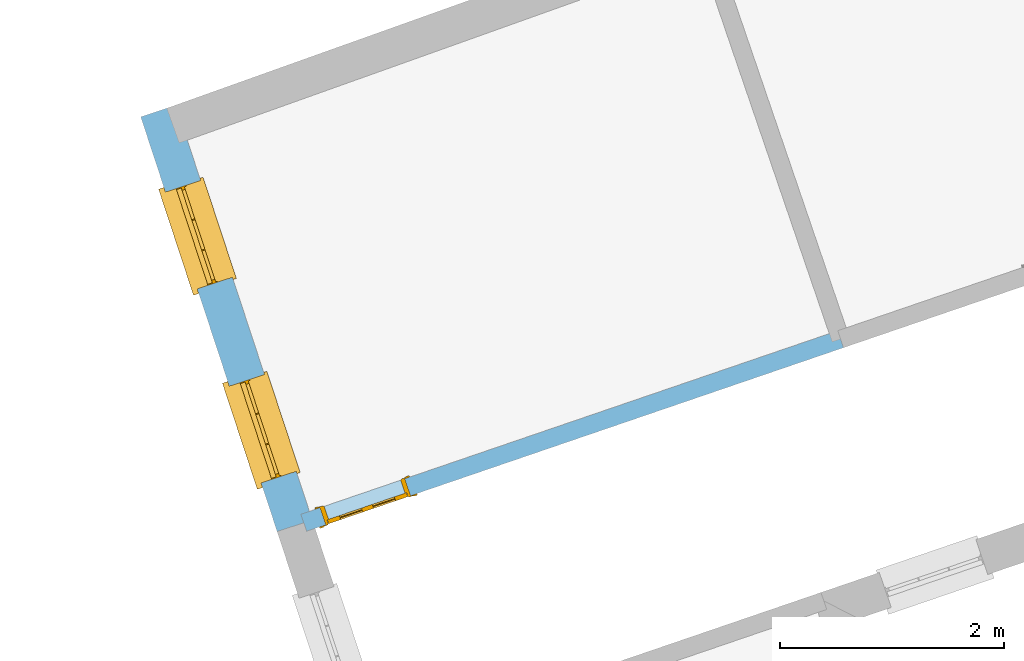
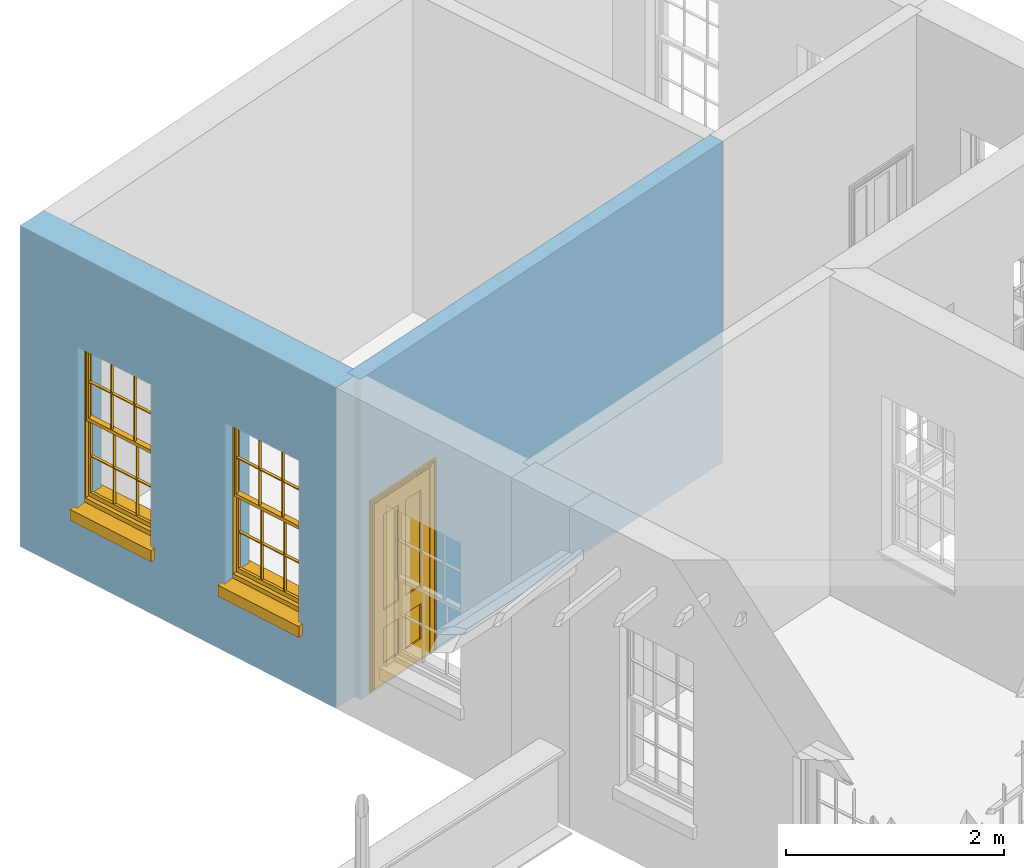
# One storey, part 6 of 10: 2 windows, 1 door, 3 openings, plus 2 elements that do not belong to this part.
"""IFC2X3 building model written with IfcOpenShell, lengths in metres."""

from ifc_helpers import new_model, si_unit, frame, origin, place, context, subcontext, project, spatial, polyline, outline, extrude, faceted_brep, material, layer, layer_set, layer_usage, element, fill, save


model = new_model("IFC2X3")

# Units and contexts
model_context = context("Model", 3, world=origin())
body_context = subcontext(model_context, "Body", "Model", "MODEL_VIEW")
ifc_project = project(units=[si_unit("PLANEANGLEUNIT", "RADIAN"), si_unit("MASSUNIT", "GRAM", prefix="KILO"), si_unit("FORCEUNIT", "NEWTON", prefix="KILO"), si_unit("LENGTHUNIT", "METRE")], contexts=[model_context])

# Site, building, storey
site_placement = place(None, origin())
site = spatial("IfcSite", under=ifc_project, at=site_placement, CompositionType="ELEMENT")
building_placement = place(None, origin())
building = spatial("IfcBuilding", under=site, at=building_placement, Name="Building plot-2", CompositionType="ELEMENT")
storey_placement = place(None, frame((0.0, 0.0, 4.6)))
storey = spatial("IfcBuildingStorey", under=building, at=storey_placement, Name="Floor 1", CompositionType="ELEMENT", Elevation=4.6)

# Wall, openings, windows
ifc_material_1 = material(Name="Masonry")
ifc_layer_1 = layer(ifc_material_1, 0.33, ventilated=False)
ifc_layer_set_1 = layer_set([ifc_layer_1], Name="My Wall")
ifc_layer_usage_1 = layer_usage(ifc_layer_set_1, "AXIS2", "NEGATIVE", 0.08)
wall_1_placement = place(storey_placement, origin())
wall_1 = element("IfcWallStandardCase", 1, at=wall_1_placement, inside=storey, material=ifc_layer_usage_1, Name="exterior", context=body_context, shape_type="SweptSolid", body=[
    extrude(outline(polyline([(27.5493804790374, 37.1006395888727), (27.2359079930561, 36.9975134499325), (28.4528876869268, 33.2982607294562), (28.7663601729081, 33.4013868683963), (27.5493804790374, 37.1006395888727)])), origin(), (0.0, 0.0, 1.0), 3.6),
])
opening_1_placement = place(storey_placement, frame((0.0, 0.0, 0.75)))
opening_1 = element("IfcOpeningElement", 2, at=opening_1_placement, cuts=wall_1, Name="Opening", ObjectType="Opening", context=body_context, shape_type="SweptSolid", body=[
    extrude(outline(polyline([(27.456558243292, 36.3268029667832), (27.7409363840057, 35.4623788387741), (28.054408869987, 35.5655049777142), (27.7700307292734, 36.4299291057233), (27.456558243292, 36.3268029667832)])), origin(), (0.0, 0.0, 1.0), 1.82),
])
opening_2_placement = place(storey_placement, frame((0.0, 0.0, 0.75)))
opening_2 = element("IfcOpeningElement", 3, at=opening_2_placement, cuts=wall_1, Name="Opening", ObjectType="Opening", context=body_context, shape_type="SweptSolid", body=[
    extrude(outline(polyline([(28.0259851588106, 34.5959161845682), (28.3103632995243, 33.7314920565591), (28.6238357855056, 33.8346181954992), (28.339457644792, 34.6990423235083), (28.0259851588106, 34.5959161845682)])), origin(), (0.0, 0.0, 1.0), 1.82),
])
window_1_placement = place(storey_placement, frame((27.6940373993385, 36.4049288296166, 0.75), z_axis=(0.0, 0.0, 1.0), x_axis=(0.284378140713617, -0.864424128009077, 0.0)))
window_1 = element("IfcWindow", 4, at=window_1_placement, inside=storey, Name="bedroom outside window", OverallHeight=1.82, OverallWidth=0.91, context=body_context, shape_type="Brep", held_by="IfcProductRepresentation", body=[
    faceted_brep([(0.033125, -0.105, 0.975209), (0.01, -0.105, 0.975209), (0.033125, -0.105, 1.376042), (0.876875, -0.105, 0.975209), (0.876875, -0.105, 1.376042), (0.9, -0.105, 0.975209), (0.876875, -0.105, 1.386042), (0.876875, -0.105, 1.786875), (0.9, -0.105, 1.81), (0.033125, -0.105, 1.786875), (0.033125, -0.105, 1.386042), (0.01, -0.105, 1.81), (0.876875, -0.135, 1.376042), (0.876875, -0.135, 0.975209), (0.9, -0.135, 0.937083), (0.033125, -0.135, 1.786875), (0.01, -0.135, 1.81), (0.033125, -0.135, 1.386042), (0.01, -0.135, 0.937083), (0.033125, -0.135, 0.975209), (0.033125, -0.135, 1.376042), (0.876875, -0.135, 1.786875), (0.876875, -0.135, 1.386042), (0.9, -0.135, 1.81), (0.033125, -0.105, 0.937083), (0.01, -0.105, 0.937083), (0.033125, -0.105, 0.53625), (0.876875, -0.105, 0.937083), (0.876875, -0.105, 0.53625), (0.9, -0.105, 0.937083), (0.876875, -0.105, 0.52625), (0.876875, -0.105, 0.125417), (0.9, -0.105, 0.077167), (0.033125, -0.105, 0.125417), (0.033125, -0.105, 0.52625), (0.01, -0.105, 0.077167), (-0.0425, -0.25, 0.01), (-0.0425, -0.3, 0.001667), (0.0, -0.25, 0.01), (0.9525, -0.25, 0.01), (0.91, -0.25, 0.01), (0.9525, -0.3, 0.001667), (-0.02, 0.08, 0.077167), (0.0, 0.08, 0.077167), (-0.02, 0.11, 0.077167), (0.0, -0.06, 0.077167), (0.01, -0.06, 0.077167), (0.91, -0.06, 0.077167), (0.91, 0.08, 0.077167), (0.9, -0.06, 0.077167), (0.93, 0.08, 0.077167), (0.93, 0.11, 0.077167), (0.01, -0.075, 0.975209), (0.9, -0.075, 0.975209), (0.876875, -0.075, 0.125417), (0.876875, -0.075, 0.52625), (0.9, -0.075, 0.077167), (0.876875, -0.075, 0.53625), (0.876875, -0.075, 0.937083), (0.033125, -0.075, 0.125417), (0.01, -0.075, 0.077167), (0.033125, -0.075, 0.52625), (0.033125, -0.075, 0.937083), (0.033125, -0.075, 0.53625), (-0.02, 0.08, 0.052167), (-0.02, 0.11, 0.052167), (0.93, 0.11, 0.052167), (0.93, 0.08, 0.052167), (0.91, 0.08, 0.052167), (0.0, 0.08, 0.052167), (0.91, -0.15, 0.026667), (0.0, -0.15, 0.026667), (-0.0425, -0.3, -0.123333), (0.9525, -0.3, -0.123333), (-0.0425, -0.25, -0.123333), (0.9525, -0.25, -0.123333), (0.01, -0.06, 1.81), (0.9, -0.06, 1.81), (0.0, -0.06, 1.82), (0.91, -0.06, 1.82), (0.01, -0.15, 0.077167), (0.9, -0.15, 0.077167), (0.592292, -0.105, 0.125417), (0.592292, -0.075, 0.125417), (0.317708, -0.075, 0.125417), (0.317708, -0.105, 0.125417), (0.592292, -0.105, 0.53625), (0.317708, -0.105, 0.53625), (0.317708, -0.105, 0.52625), (0.592292, -0.105, 0.52625), (0.592292, -0.075, 0.53625), (0.317708, -0.075, 0.53625), (0.592292, -0.135, 1.386042), (0.592292, -0.105, 1.386042), (0.317708, -0.105, 1.386042), (0.317708, -0.135, 1.386042), (0.317708, -0.135, 1.376042), (0.592292, -0.135, 1.376042), (0.317708, -0.105, 1.376042), (0.592292, -0.105, 1.376042), (0.602292, -0.135, 1.376042), (0.592292, -0.135, 0.975209), (0.602292, -0.135, 0.975209), (0.602292, -0.105, 0.975209), (0.592292, -0.105, 0.975209), (0.602292, -0.105, 1.376042), (0.602292, -0.075, 0.53625), (0.602292, -0.105, 0.53625), (0.317708, -0.075, 0.52625), (0.307708, -0.075, 0.125417), (0.307708, -0.075, 0.52625), (0.602292, -0.075, 0.52625), (0.602292, -0.075, 0.125417), (0.592292, -0.075, 0.52625), (0.307708, -0.075, 0.53625), (0.317708, -0.075, 0.937083), (0.307708, -0.075, 0.937083), (0.602292, -0.075, 0.937083), (0.592292, -0.075, 0.937083), (0.307708, -0.105, 0.52625), (0.307708, -0.105, 0.125417), (0.307708, -0.105, 0.53625), (0.307708, -0.105, 0.937083), (0.592292, -0.105, 0.937083), (0.317708, -0.105, 0.937083), (0.602292, -0.105, 0.937083), (0.602292, -0.105, 0.52625), (0.602292, -0.105, 0.125417), (0.307708, -0.135, 1.386042), (0.307708, -0.135, 1.376042), (0.307708, -0.135, 0.975209), (0.317708, -0.135, 0.975209), (0.317708, -0.135, 1.786875), (0.307708, -0.135, 1.786875), (0.602292, -0.135, 1.786875), (0.592292, -0.135, 1.786875), (0.602292, -0.135, 1.386042), (0.602292, -0.105, 1.386042), (0.307708, -0.105, 1.386042), (0.307708, -0.105, 1.786875), (0.317708, -0.105, 1.786875), (0.592292, -0.105, 1.786875), (0.602292, -0.105, 1.786875), (0.307708, -0.105, 1.376042), (0.317708, -0.105, 0.975209), (0.307708, -0.105, 0.975209), (0.91, -0.15, 1.82), (0.9, -0.15, 1.81), (0.01, -0.15, 1.81), (0.0, -0.15, 1.82), (0.91, -0.25, 0.0), (0.0, -0.25, 0.0), (0.91, 0.08, 0.0), (0.0, 0.08, 0.0)], [[[0, 1, 2]], [[3, 4, 5]], [[6, 7, 8]], [[9, 10, 11]], [[12, 13, 14]], [[15, 16, 17]], [[18, 19, 20]], [[21, 22, 23]], [[24, 25, 26]], [[27, 28, 29]], [[30, 31, 32]], [[33, 34, 35]], [[14, 27, 29]], [[25, 24, 18]], [[36, 37, 38]], [[39, 40, 41]], [[42, 43, 44]], [[45, 46, 43]], [[47, 48, 49]], [[50, 51, 48]], [[1, 0, 52]], [[5, 53, 3]], [[54, 55, 56]], [[57, 58, 53]], [[59, 60, 61]], [[62, 63, 52]], [[48, 43, 46, 49]], [[51, 44, 43, 48]], [[64, 42, 44, 65]], [[65, 44, 51, 66]], [[66, 51, 50, 67]], [[65, 66, 68, 69]], [[60, 56, 49, 46]], [[70, 71, 38, 40]], [[37, 41, 40, 38]], [[37, 72, 73, 41]], [[74, 75, 73, 72]], [[8, 11, 76, 77]], [[76, 78, 79, 77]], [[32, 35, 80, 81]], [[81, 80, 71, 70]], [[82, 83, 84, 85]], [[86, 87, 88, 89]], [[86, 90, 91, 87]], [[92, 93, 94, 95]], [[92, 95, 96, 97]], [[96, 98, 99, 97]], [[100, 97, 101, 102]], [[103, 104, 99, 105]], [[97, 99, 104, 101]], [[102, 103, 105, 100]], [[28, 57, 106, 107]], [[108, 84, 109, 110]], [[111, 112, 83, 113]], [[114, 110, 61, 63]], [[90, 113, 108, 91]], [[115, 91, 114, 116]], [[117, 106, 90, 118]], [[111, 106, 57, 55]], [[119, 110, 109, 120]], [[34, 61, 110, 119]], [[89, 113, 83, 82]], [[88, 108, 113, 89]], [[85, 84, 108, 88]], [[121, 114, 63, 26]], [[122, 116, 114, 121]], [[123, 118, 90, 86]], [[87, 91, 115, 124]], [[107, 106, 117, 125]], [[126, 111, 55, 30]], [[127, 112, 111, 126]], [[126, 30, 28, 107]], [[88, 119, 120, 85]], [[126, 89, 82, 127]], [[125, 123, 86, 107]], [[121, 26, 34, 119]], [[124, 122, 121, 87]], [[128, 17, 20, 129]], [[96, 129, 130, 131]], [[132, 133, 128, 95]], [[134, 135, 92, 136]], [[100, 12, 22, 136]], [[137, 6, 4, 105]], [[94, 138, 139, 140]], [[137, 93, 141, 142]], [[99, 98, 94, 93]], [[143, 2, 10, 138]], [[144, 145, 143, 98]], [[129, 143, 145, 130]], [[20, 2, 143, 129]], [[131, 144, 98, 96]], [[128, 138, 10, 17]], [[133, 139, 138, 128]], [[135, 141, 93, 92]], [[95, 94, 140, 132]], [[22, 6, 137, 136]], [[136, 137, 142, 134]], [[100, 105, 4, 12]], [[107, 86, 89, 126]], [[106, 111, 113, 90]], [[91, 108, 110, 114]], [[87, 121, 119, 88]], [[97, 100, 136, 92]], [[129, 96, 95, 128]], [[98, 143, 138, 94]], [[105, 99, 93, 137]], [[131, 101, 104, 144]], [[124, 115, 118, 123]], [[132, 140, 141, 135]], [[120, 109, 59, 33]], [[15, 9, 139, 133]], [[134, 142, 7, 21]], [[31, 54, 112, 127]], [[36, 74, 72, 37]], [[39, 41, 73, 75]], [[18, 14, 101, 131]], [[23, 16, 132, 135]], [[83, 56, 60, 84]], [[52, 53, 118, 115]], [[53, 52, 144, 104]], [[11, 8, 141, 140]], [[14, 18, 124, 123]], [[2, 1, 11, 10]], [[8, 5, 4, 6]], [[57, 53, 56, 55]], [[60, 52, 63, 61]], [[26, 25, 35, 34]], [[32, 29, 28, 30]], [[14, 23, 22, 12]], [[18, 20, 17, 16]], [[19, 0, 2, 20]], [[17, 10, 9, 15]], [[12, 4, 3, 13]], [[21, 7, 6, 22]], [[27, 58, 57, 28]], [[30, 55, 54, 31]], [[33, 59, 61, 34]], [[26, 63, 62, 24]], [[5, 8, 77, 53]], [[76, 11, 1, 52]], [[46, 45, 78, 76]], [[49, 77, 79, 47]], [[70, 146, 147, 81]], [[71, 80, 148, 149]], [[19, 130, 145, 0]], [[102, 13, 3, 103]], [[116, 122, 24, 62]], [[29, 32, 81, 14]], [[80, 35, 25, 18]], [[60, 46, 76, 52]], [[77, 49, 56, 53]], [[23, 14, 81, 147]], [[16, 148, 80, 18]], [[35, 85, 120]], [[120, 33, 35]], [[127, 82, 32]], [[32, 31, 127]], [[32, 82, 85, 35]], [[102, 101, 14]], [[14, 13, 102]], [[18, 131, 130]], [[130, 19, 18]], [[134, 21, 23]], [[23, 135, 134]], [[16, 15, 133]], [[133, 132, 16]], [[11, 140, 139]], [[139, 9, 11]], [[142, 141, 8]], [[8, 7, 142]], [[23, 147, 148, 16]], [[146, 149, 148, 147]], [[52, 115, 116]], [[116, 62, 52]], [[118, 53, 117]], [[58, 117, 53]], [[27, 125, 117, 58]], [[56, 83, 112]], [[112, 54, 56]], [[109, 84, 60]], [[60, 59, 109]], [[125, 27, 14]], [[14, 123, 125]], [[122, 124, 18]], [[18, 24, 122]], [[145, 144, 52]], [[52, 0, 145]], [[103, 3, 53]], [[53, 104, 103]], [[79, 78, 149, 146]], [[78, 45, 71, 149]], [[146, 70, 47, 79]], [[150, 75, 74, 151]], [[68, 66, 67]], [[48, 68, 67, 50]], [[69, 64, 65]], [[42, 64, 69, 43]], [[69, 68, 152, 153]], [[70, 68, 48, 47]], [[150, 152, 68, 70]], [[43, 69, 71, 45]], [[69, 153, 151, 71]], [[152, 150, 151, 153]], [[38, 151, 74, 36]], [[71, 151, 38]], [[39, 75, 150, 40]], [[40, 150, 70]]]),
])
fill(opening_1, window_1)
window_2_placement = place(storey_placement, frame((28.2634643148571, 34.6740420474016, 0.75), z_axis=(0.0, 0.0, 1.0), x_axis=(0.284378140713617, -0.864424128009077, 0.0)))
window_2 = element("IfcWindow", 5, at=window_2_placement, inside=storey, Name="bedroom outside window", OverallHeight=1.82, OverallWidth=0.91, context=body_context, shape_type="Brep", held_by="IfcProductRepresentation", body=[
    faceted_brep([(0.033125, -0.105, 0.975209), (0.01, -0.105, 0.975209), (0.033125, -0.105, 1.376042), (0.876875, -0.105, 0.975209), (0.876875, -0.105, 1.376042), (0.9, -0.105, 0.975209), (0.876875, -0.105, 1.386042), (0.876875, -0.105, 1.786875), (0.9, -0.105, 1.81), (0.033125, -0.105, 1.786875), (0.033125, -0.105, 1.386042), (0.01, -0.105, 1.81), (0.876875, -0.135, 1.376042), (0.876875, -0.135, 0.975209), (0.9, -0.135, 0.937083), (0.033125, -0.135, 1.786875), (0.01, -0.135, 1.81), (0.033125, -0.135, 1.386042), (0.01, -0.135, 0.937083), (0.033125, -0.135, 0.975209), (0.033125, -0.135, 1.376042), (0.876875, -0.135, 1.786875), (0.876875, -0.135, 1.386042), (0.9, -0.135, 1.81), (0.033125, -0.105, 0.937083), (0.01, -0.105, 0.937083), (0.033125, -0.105, 0.53625), (0.876875, -0.105, 0.937083), (0.876875, -0.105, 0.53625), (0.9, -0.105, 0.937083), (0.876875, -0.105, 0.52625), (0.876875, -0.105, 0.125417), (0.9, -0.105, 0.077167), (0.033125, -0.105, 0.125417), (0.033125, -0.105, 0.52625), (0.01, -0.105, 0.077167), (-0.0425, -0.25, 0.01), (-0.0425, -0.3, 0.001667), (0.0, -0.25, 0.01), (0.9525, -0.25, 0.01), (0.91, -0.25, 0.01), (0.9525, -0.3, 0.001667), (-0.02, 0.08, 0.077167), (0.0, 0.08, 0.077167), (-0.02, 0.11, 0.077167), (0.0, -0.06, 0.077167), (0.01, -0.06, 0.077167), (0.91, -0.06, 0.077167), (0.91, 0.08, 0.077167), (0.9, -0.06, 0.077167), (0.93, 0.08, 0.077167), (0.93, 0.11, 0.077167), (0.01, -0.075, 0.975209), (0.9, -0.075, 0.975209), (0.876875, -0.075, 0.125417), (0.876875, -0.075, 0.52625), (0.9, -0.075, 0.077167), (0.876875, -0.075, 0.53625), (0.876875, -0.075, 0.937083), (0.033125, -0.075, 0.125417), (0.01, -0.075, 0.077167), (0.033125, -0.075, 0.52625), (0.033125, -0.075, 0.937083), (0.033125, -0.075, 0.53625), (-0.02, 0.08, 0.052167), (-0.02, 0.11, 0.052167), (0.93, 0.11, 0.052167), (0.93, 0.08, 0.052167), (0.91, 0.08, 0.052167), (0.0, 0.08, 0.052167), (0.91, -0.15, 0.026667), (0.0, -0.15, 0.026667), (-0.0425, -0.3, -0.123333), (0.9525, -0.3, -0.123333), (-0.0425, -0.25, -0.123333), (0.9525, -0.25, -0.123333), (0.01, -0.06, 1.81), (0.9, -0.06, 1.81), (0.0, -0.06, 1.82), (0.91, -0.06, 1.82), (0.01, -0.15, 0.077167), (0.9, -0.15, 0.077167), (0.592292, -0.105, 0.125417), (0.592292, -0.075, 0.125417), (0.317708, -0.075, 0.125417), (0.317708, -0.105, 0.125417), (0.592292, -0.105, 0.53625), (0.317708, -0.105, 0.53625), (0.317708, -0.105, 0.52625), (0.592292, -0.105, 0.52625), (0.592292, -0.075, 0.53625), (0.317708, -0.075, 0.53625), (0.592292, -0.135, 1.386042), (0.592292, -0.105, 1.386042), (0.317708, -0.105, 1.386042), (0.317708, -0.135, 1.386042), (0.317708, -0.135, 1.376042), (0.592292, -0.135, 1.376042), (0.317708, -0.105, 1.376042), (0.592292, -0.105, 1.376042), (0.602292, -0.135, 1.376042), (0.592292, -0.135, 0.975209), (0.602292, -0.135, 0.975209), (0.602292, -0.105, 0.975209), (0.592292, -0.105, 0.975209), (0.602292, -0.105, 1.376042), (0.602292, -0.075, 0.53625), (0.602292, -0.105, 0.53625), (0.317708, -0.075, 0.52625), (0.307708, -0.075, 0.125417), (0.307708, -0.075, 0.52625), (0.602292, -0.075, 0.52625), (0.602292, -0.075, 0.125417), (0.592292, -0.075, 0.52625), (0.307708, -0.075, 0.53625), (0.317708, -0.075, 0.937083), (0.307708, -0.075, 0.937083), (0.602292, -0.075, 0.937083), (0.592292, -0.075, 0.937083), (0.307708, -0.105, 0.52625), (0.307708, -0.105, 0.125417), (0.307708, -0.105, 0.53625), (0.307708, -0.105, 0.937083), (0.592292, -0.105, 0.937083), (0.317708, -0.105, 0.937083), (0.602292, -0.105, 0.937083), (0.602292, -0.105, 0.52625), (0.602292, -0.105, 0.125417), (0.307708, -0.135, 1.386042), (0.307708, -0.135, 1.376042), (0.307708, -0.135, 0.975209), (0.317708, -0.135, 0.975209), (0.317708, -0.135, 1.786875), (0.307708, -0.135, 1.786875), (0.602292, -0.135, 1.786875), (0.592292, -0.135, 1.786875), (0.602292, -0.135, 1.386042), (0.602292, -0.105, 1.386042), (0.307708, -0.105, 1.386042), (0.307708, -0.105, 1.786875), (0.317708, -0.105, 1.786875), (0.592292, -0.105, 1.786875), (0.602292, -0.105, 1.786875), (0.307708, -0.105, 1.376042), (0.317708, -0.105, 0.975209), (0.307708, -0.105, 0.975209), (0.91, -0.15, 1.82), (0.9, -0.15, 1.81), (0.01, -0.15, 1.81), (0.0, -0.15, 1.82), (0.91, -0.25, 0.0), (0.0, -0.25, 0.0), (0.91, 0.08, 0.0), (0.0, 0.08, 0.0)], [[[0, 1, 2]], [[3, 4, 5]], [[6, 7, 8]], [[9, 10, 11]], [[12, 13, 14]], [[15, 16, 17]], [[18, 19, 20]], [[21, 22, 23]], [[24, 25, 26]], [[27, 28, 29]], [[30, 31, 32]], [[33, 34, 35]], [[14, 27, 29]], [[25, 24, 18]], [[36, 37, 38]], [[39, 40, 41]], [[42, 43, 44]], [[45, 46, 43]], [[47, 48, 49]], [[50, 51, 48]], [[1, 0, 52]], [[5, 53, 3]], [[54, 55, 56]], [[57, 58, 53]], [[59, 60, 61]], [[62, 63, 52]], [[48, 43, 46, 49]], [[51, 44, 43, 48]], [[64, 42, 44, 65]], [[65, 44, 51, 66]], [[66, 51, 50, 67]], [[65, 66, 68, 69]], [[60, 56, 49, 46]], [[70, 71, 38, 40]], [[37, 41, 40, 38]], [[37, 72, 73, 41]], [[74, 75, 73, 72]], [[8, 11, 76, 77]], [[76, 78, 79, 77]], [[32, 35, 80, 81]], [[81, 80, 71, 70]], [[82, 83, 84, 85]], [[86, 87, 88, 89]], [[86, 90, 91, 87]], [[92, 93, 94, 95]], [[92, 95, 96, 97]], [[96, 98, 99, 97]], [[100, 97, 101, 102]], [[103, 104, 99, 105]], [[97, 99, 104, 101]], [[102, 103, 105, 100]], [[28, 57, 106, 107]], [[108, 84, 109, 110]], [[111, 112, 83, 113]], [[114, 110, 61, 63]], [[90, 113, 108, 91]], [[115, 91, 114, 116]], [[117, 106, 90, 118]], [[111, 106, 57, 55]], [[119, 110, 109, 120]], [[34, 61, 110, 119]], [[89, 113, 83, 82]], [[88, 108, 113, 89]], [[85, 84, 108, 88]], [[121, 114, 63, 26]], [[122, 116, 114, 121]], [[123, 118, 90, 86]], [[87, 91, 115, 124]], [[107, 106, 117, 125]], [[126, 111, 55, 30]], [[127, 112, 111, 126]], [[126, 30, 28, 107]], [[88, 119, 120, 85]], [[126, 89, 82, 127]], [[125, 123, 86, 107]], [[121, 26, 34, 119]], [[124, 122, 121, 87]], [[128, 17, 20, 129]], [[96, 129, 130, 131]], [[132, 133, 128, 95]], [[134, 135, 92, 136]], [[100, 12, 22, 136]], [[137, 6, 4, 105]], [[94, 138, 139, 140]], [[137, 93, 141, 142]], [[99, 98, 94, 93]], [[143, 2, 10, 138]], [[144, 145, 143, 98]], [[129, 143, 145, 130]], [[20, 2, 143, 129]], [[131, 144, 98, 96]], [[128, 138, 10, 17]], [[133, 139, 138, 128]], [[135, 141, 93, 92]], [[95, 94, 140, 132]], [[22, 6, 137, 136]], [[136, 137, 142, 134]], [[100, 105, 4, 12]], [[107, 86, 89, 126]], [[106, 111, 113, 90]], [[91, 108, 110, 114]], [[87, 121, 119, 88]], [[97, 100, 136, 92]], [[129, 96, 95, 128]], [[98, 143, 138, 94]], [[105, 99, 93, 137]], [[131, 101, 104, 144]], [[124, 115, 118, 123]], [[132, 140, 141, 135]], [[120, 109, 59, 33]], [[15, 9, 139, 133]], [[134, 142, 7, 21]], [[31, 54, 112, 127]], [[36, 74, 72, 37]], [[39, 41, 73, 75]], [[18, 14, 101, 131]], [[23, 16, 132, 135]], [[83, 56, 60, 84]], [[52, 53, 118, 115]], [[53, 52, 144, 104]], [[11, 8, 141, 140]], [[14, 18, 124, 123]], [[2, 1, 11, 10]], [[8, 5, 4, 6]], [[57, 53, 56, 55]], [[60, 52, 63, 61]], [[26, 25, 35, 34]], [[32, 29, 28, 30]], [[14, 23, 22, 12]], [[18, 20, 17, 16]], [[19, 0, 2, 20]], [[17, 10, 9, 15]], [[12, 4, 3, 13]], [[21, 7, 6, 22]], [[27, 58, 57, 28]], [[30, 55, 54, 31]], [[33, 59, 61, 34]], [[26, 63, 62, 24]], [[5, 8, 77, 53]], [[76, 11, 1, 52]], [[46, 45, 78, 76]], [[49, 77, 79, 47]], [[70, 146, 147, 81]], [[71, 80, 148, 149]], [[19, 130, 145, 0]], [[102, 13, 3, 103]], [[116, 122, 24, 62]], [[29, 32, 81, 14]], [[80, 35, 25, 18]], [[60, 46, 76, 52]], [[77, 49, 56, 53]], [[23, 14, 81, 147]], [[16, 148, 80, 18]], [[35, 85, 120]], [[120, 33, 35]], [[127, 82, 32]], [[32, 31, 127]], [[32, 82, 85, 35]], [[102, 101, 14]], [[14, 13, 102]], [[18, 131, 130]], [[130, 19, 18]], [[134, 21, 23]], [[23, 135, 134]], [[16, 15, 133]], [[133, 132, 16]], [[11, 140, 139]], [[139, 9, 11]], [[142, 141, 8]], [[8, 7, 142]], [[23, 147, 148, 16]], [[146, 149, 148, 147]], [[52, 115, 116]], [[116, 62, 52]], [[118, 53, 117]], [[58, 117, 53]], [[27, 125, 117, 58]], [[56, 83, 112]], [[112, 54, 56]], [[109, 84, 60]], [[60, 59, 109]], [[125, 27, 14]], [[14, 123, 125]], [[122, 124, 18]], [[18, 24, 122]], [[145, 144, 52]], [[52, 0, 145]], [[103, 3, 53]], [[53, 104, 103]], [[79, 78, 149, 146]], [[78, 45, 71, 149]], [[146, 70, 47, 79]], [[150, 75, 74, 151]], [[68, 66, 67]], [[48, 68, 67, 50]], [[69, 64, 65]], [[42, 64, 69, 43]], [[69, 68, 152, 153]], [[70, 68, 48, 47]], [[150, 152, 68, 70]], [[43, 69, 71, 45]], [[69, 153, 151, 71]], [[152, 150, 151, 153]], [[38, 151, 74, 36]], [[71, 151, 38]], [[39, 75, 150, 40]], [[40, 150, 70]]]),
])
fill(opening_2, window_2)

# Wall, opening, door
ifc_material_2 = material(Name="Masonry")
ifc_layer_2 = layer(ifc_material_2, 0.16, ventilated=False)
ifc_layer_set_2 = layer_set([ifc_layer_2], Name="My Wall")
ifc_layer_usage_2 = layer_usage(ifc_layer_set_2, "AXIS2", "NEGATIVE", 0.08)
wall_2_placement = place(storey_placement, origin())
wall_2 = element("IfcWallStandardCase", 6, at=wall_2_placement, inside=storey, material=ifc_layer_usage_2, Name="interior", context=body_context, shape_type="SweptSolid", body=[
    extrude(outline(polyline([(33.5051048113054, 34.9381128612349), (33.4533393772504, 35.0895075105363), (28.6644841259457, 33.4520839169403), (28.7162495600007, 33.3006892676389), (33.5051048113054, 34.9381128612349)])), origin(), (0.0, 0.0, 1.0), 3.6),
])
opening_3_placement = place(storey_placement, frame((0.0, 0.0, 0.0199999999999996)))
opening_3 = element("IfcOpeningElement", 7, at=opening_3_placement, cuts=wall_2, Name="Opening", ObjectType="Opening", context=body_context, shape_type="SweptSolid", body=[
    extrude(outline(polyline([(29.5917763529169, 33.7691472005271), (28.8348031064098, 33.5103200302522), (28.8865685404648, 33.3589253809508), (29.6435417869719, 33.6177525512257), (29.5917763529169, 33.7691472005271)])), origin(), (0.0, 0.0, 1.0), 2.1),
])
door_placement = place(storey_placement, frame((29.6176590699444, 33.6934498758764, 0.0199999999999996), z_axis=(0.0, 0.0, 1.0), x_axis=(-0.756973246507066, -0.258827170274969, 0.0)))
door = element("IfcDoor", 8, at=door_placement, inside=storey, Name="bedroom inside door", OverallHeight=2.1, OverallWidth=0.8, context=body_context, shape_type="Brep", held_by="IfcProductRepresentation", body=[
    faceted_brep([(0.773, 0.08, 1.895), (0.66, 0.08, 1.895), (0.66, 0.08, 2.073), (0.773, 0.08, 2.073), (0.773, 0.08, 0.82), (0.66, 0.08, 0.82), (0.45, 0.08, 1.895), (0.45, 0.08, 2.073), (0.773, 0.08, 0.62), (0.66, 0.08, 0.62), (0.66, 0.065, 0.82), (0.66, 0.065, 1.895), (0.45, 0.065, 1.895), (0.35, 0.08, 1.895), (0.35, 0.08, 2.073), (0.773, 0.08, 0.225), (0.66, 0.08, 0.225), (0.45, 0.08, 0.62), (0.45, 0.08, 0.82), (0.45, 0.065, 0.82), (0.35, 0.08, 0.82), (0.14, 0.08, 2.073), (0.14, 0.08, 1.895), (0.773, 0.08, 0.0), (0.66, 0.08, 0.0), (0.66, 0.065, 0.225), (0.66, 0.065, 0.62), (0.45, 0.065, 0.62), (0.35, 0.08, 0.62), (0.35, 0.065, 0.82), (0.35, 0.065, 1.895), (0.14, 0.065, 1.895), (0.027, 0.08, 2.073), (0.027, 0.08, 1.895), (0.773, 0.042, 0.0), (0.66, 0.042, 0.0), (0.45, 0.08, 0.0), (0.45, 0.08, 0.225), (0.45, 0.065, 0.225), (0.35, 0.08, 0.225), (0.14, 0.08, 0.82), (0.14, 0.08, 0.62), (0.14, 0.065, 0.82), (0.027, 0.08, 0.82), (0.773, 0.042, 0.225), (0.66, 0.042, 0.225), (0.45, 0.042, 0.0), (0.35, 0.08, 0.0), (0.35, 0.065, 0.225), (0.35, 0.065, 0.62), (0.14, 0.065, 0.62), (0.027, 0.08, 0.62), (0.773, 0.042, 0.62), (0.66, 0.042, 0.62), (0.45, 0.042, 0.225), (0.35, 0.042, 0.0), (0.14, 0.08, 0.225), (0.14, 0.08, 0.0), (0.14, 0.065, 0.225), (0.027, 0.08, 0.225), (0.773, 0.042, 0.82), (0.66, 0.042, 0.82), (0.66, 0.057, 0.62), (0.66, 0.057, 0.225), (0.45, 0.057, 0.225), (0.35, 0.042, 0.225), (0.14, 0.042, 0.0), (0.027, 0.08, 0.0), (0.773, 0.042, 1.895), (0.66, 0.042, 1.895), (0.45, 0.042, 0.62), (0.45, 0.042, 0.82), (0.45, 0.057, 0.62), (0.35, 0.042, 0.62), (0.14, 0.042, 0.225), (0.027, 0.042, 0.0), (0.773, 0.042, 2.073), (0.66, 0.042, 2.073), (0.66, 0.057, 1.895), (0.66, 0.057, 0.82), (0.45, 0.057, 0.82), (0.35, 0.042, 0.82), (0.35, 0.057, 0.62), (0.35, 0.057, 0.225), (0.14, 0.057, 0.225), (0.027, 0.042, 0.225), (0.45, 0.042, 1.895), (0.45, 0.042, 2.073), (0.45, 0.057, 1.895), (0.35, 0.042, 1.895), (0.14, 0.042, 0.82), (0.14, 0.042, 0.62), (0.14, 0.057, 0.62), (0.027, 0.042, 0.62), (0.35, 0.042, 2.073), (0.35, 0.057, 1.895), (0.35, 0.057, 0.82), (0.14, 0.057, 0.82), (0.027, 0.042, 0.82), (0.14, 0.042, 2.073), (0.14, 0.042, 1.895), (0.14, 0.057, 1.895), (0.027, 0.042, 1.895), (0.027, 0.042, 2.073), (0.02, 0.085, 0.0), (0.005, 0.09, 0.0), (0.005, 0.09, 2.095), (0.02, 0.085, 2.08), (0.02, 0.08, 0.0), (0.0, 0.085, 0.0), (0.0, 0.085, 2.1), (0.795, 0.09, 2.095), (0.78, 0.085, 2.08), (0.02, 0.08, 2.08), (0.0, 0.08, 0.0), (-0.032, 0.095, 0.0), (-0.032, 0.095, 2.132), (0.8, 0.085, 2.1), (0.795, 0.09, 0.0), (0.78, 0.085, 0.0), (0.78, 0.08, 2.08), (0.04, 0.04, 0.0), (0.025, 0.04, 0.0), (0.025, 0.04, 2.075), (0.04, 0.04, 2.06), (-0.04, 0.09, 0.0), (-0.04, 0.09, 2.14), (0.832, 0.095, 2.132), (0.8, 0.085, 0.0), (0.78, 0.08, 0.0), (0.8, 0.08, 0.0), (0.86, 0.08, 0.0), (0.86, 0.08, 2.16), (0.8, 0.08, 2.1), (-0.06, 0.08, 2.16), (0.0, 0.08, 2.1), (-0.06, 0.08, 0.0), (-0.04, 0.095, 0.0), (-0.04, 0.095, 2.14), (0.84, 0.09, 2.14), (0.832, 0.095, 0.0), (0.84, 0.09, 0.0), (0.86, 0.095, 0.0), (0.86, 0.095, 2.16), (-0.06, 0.095, 2.16), (-0.06, 0.095, 0.0), (0.84, 0.095, 0.0), (0.84, 0.095, 2.14), (-0.025, -0.095, 0.0), (-0.025, -0.09, 0.0), (-0.025, -0.09, 2.125), (-0.025, -0.095, 2.125), (-0.017, -0.095, 0.0), (-0.017, -0.095, 2.117), (0.825, -0.09, 2.125), (0.825, -0.095, 2.125), (0.825, -0.095, 0.0), (0.845, -0.095, 0.0), (-0.045, -0.095, 2.145), (-0.045, -0.095, 0.0), (0.845, -0.095, 2.145), (0.015, -0.085, 0.0), (0.015, -0.085, 2.085), (0.817, -0.095, 2.117), (0.825, -0.09, 0.0), (0.845, -0.08, 0.0), (0.845, -0.08, 2.145), (-0.045, -0.08, 2.145), (-0.045, -0.08, 0.0), (0.02, -0.09, 0.0), (0.02, -0.09, 2.08), (0.785, -0.085, 2.085), (0.817, -0.095, 0.0), (0.8, -0.08, 0.0), (0.8, -0.08, 2.1), (0.0, -0.08, 2.1), (0.0, -0.08, 0.0), (0.035, -0.085, 0.0), (0.035, -0.085, 2.065), (0.78, -0.09, 2.08), (0.785, -0.085, 0.0), (0.775, 0.04, 2.075), (0.76, 0.04, 2.06), (0.035, -0.08, 2.065), (0.035, -0.08, 0.0), (0.765, -0.085, 2.065), (0.78, -0.09, 0.0), (0.765, -0.08, 0.0), (0.765, -0.08, 2.065), (0.765, -0.085, 0.0), (0.04, -0.08, 2.06), (0.04, -0.08, 0.0), (0.76, -0.08, 2.06), (0.76, -0.08, 0.0), (0.76, 0.04, 0.0), (0.775, 0.04, 0.0), (0.025, 0.08, 0.0), (0.025, 0.08, 2.075), (0.775, 0.08, 0.0), (0.775, 0.08, 2.075)], [[[0, 1, 2, 3]], [[1, 0, 4, 5]], [[1, 6, 7, 2]], [[8, 9, 5, 4]], [[1, 5, 10, 11]], [[6, 1, 11, 12]], [[6, 13, 14, 7]], [[15, 16, 9, 8]], [[9, 17, 18, 5]], [[5, 18, 19, 10]], [[10, 19, 12, 11]], [[18, 6, 12, 19]], [[18, 20, 13, 6]], [[21, 14, 13, 22]], [[23, 24, 16, 15]], [[9, 16, 25, 26]], [[17, 9, 26, 27]], [[17, 28, 20, 18]], [[13, 20, 29, 30]], [[22, 13, 30, 31]], [[32, 21, 22, 33]], [[34, 35, 24, 23]], [[24, 36, 37, 16]], [[16, 37, 38, 25]], [[25, 38, 27, 26]], [[37, 17, 27, 38]], [[37, 39, 28, 17]], [[40, 20, 28, 41]], [[20, 40, 42, 29]], [[31, 30, 29, 42]], [[40, 22, 31, 42]], [[33, 22, 40, 43]], [[35, 34, 44, 45]], [[35, 46, 36, 24]], [[36, 47, 39, 37]], [[28, 39, 48, 49]], [[41, 28, 49, 50]], [[43, 40, 41, 51]], [[45, 44, 52, 53]], [[46, 35, 45, 54]], [[46, 55, 47, 36]], [[56, 39, 47, 57]], [[39, 56, 58, 48]], [[50, 49, 48, 58]], [[56, 41, 50, 58]], [[51, 41, 56, 59]], [[53, 52, 60, 61]], [[45, 53, 62, 63]], [[54, 45, 63, 64]], [[55, 46, 54, 65]], [[55, 66, 57, 47]], [[59, 56, 57, 67]], [[61, 60, 68, 69]], [[70, 53, 61, 71]], [[53, 70, 72, 62]], [[72, 64, 63, 62]], [[70, 54, 64, 72]], [[65, 54, 70, 73]], [[65, 74, 66, 55]], [[67, 57, 66, 75]], [[69, 68, 76, 77]], [[61, 69, 78, 79]], [[71, 61, 79, 80]], [[73, 70, 71, 81]], [[65, 73, 82, 83]], [[74, 65, 83, 84]], [[74, 85, 75, 66]], [[86, 69, 77, 87]], [[69, 86, 88, 78]], [[88, 80, 79, 78]], [[86, 71, 80, 88]], [[81, 71, 86, 89]], [[73, 81, 90, 91]], [[73, 91, 92, 82]], [[83, 82, 92, 84]], [[91, 74, 84, 92]], [[91, 93, 85, 74]], [[89, 86, 87, 94]], [[81, 89, 95, 96]], [[90, 81, 96, 97]], [[90, 98, 93, 91]], [[94, 99, 100, 89]], [[89, 100, 101, 95]], [[101, 97, 96, 95]], [[100, 90, 97, 101]], [[100, 102, 98, 90]], [[99, 103, 102, 100]], [[32, 103, 99, 21]], [[102, 103, 32, 33]], [[98, 102, 33, 43]], [[21, 99, 94, 14]], [[94, 87, 7, 14]], [[7, 87, 77, 2]], [[76, 3, 2, 77]], [[43, 51, 93, 98]], [[51, 59, 85, 93]], [[67, 75, 85, 59]], [[34, 23, 15, 44]], [[44, 15, 8, 52]], [[52, 8, 4, 60]], [[0, 68, 60, 4]], [[0, 3, 76, 68]], [[104, 105, 106, 107]], [[104, 108, 109, 105]], [[105, 109, 110, 106]], [[107, 106, 111, 112]], [[107, 113, 108, 104]], [[114, 109, 108]], [[109, 115, 116, 110]], [[106, 110, 117, 111]], [[112, 111, 118, 119]], [[113, 107, 112, 120]], [[121, 122, 123, 124]], [[115, 109, 114, 125]], [[115, 125, 126, 116]], [[110, 116, 127, 117]], [[111, 117, 128, 118]], [[118, 128, 129, 119]], [[120, 112, 119, 129]], [[130, 129, 128]], [[130, 131, 132, 133]], [[133, 132, 134, 135]], [[135, 134, 136, 114]], [[136, 125, 114]], [[125, 137, 138, 126]], [[116, 126, 139, 127]], [[117, 127, 140, 128]], [[141, 130, 128, 140]], [[131, 130, 141]], [[131, 142, 143, 132]], [[132, 143, 144, 134]], [[134, 144, 145, 136]], [[137, 125, 136, 145]], [[143, 142, 146]], [[143, 146, 147]], [[137, 145, 144]], [[143, 147, 138]], [[138, 137, 144]], [[143, 138, 144]], [[126, 138, 147, 139]], [[127, 139, 141, 140]], [[142, 131, 141, 146]], [[139, 147, 146, 141]], [[148, 149, 150, 151]], [[149, 152, 153, 150]], [[151, 150, 154, 155]], [[155, 156, 157]], [[158, 159, 148]], [[158, 148, 151]], [[155, 157, 160]], [[158, 151, 155]], [[155, 160, 158]], [[152, 161, 162, 153]], [[150, 153, 163, 154]], [[155, 154, 164, 156]], [[156, 164, 165, 157]], [[157, 165, 166, 160]], [[160, 166, 167, 158]], [[158, 167, 168, 159]], [[161, 169, 170, 162]], [[153, 162, 171, 163]], [[154, 163, 172, 164]], [[165, 164, 173]], [[165, 173, 174, 166]], [[166, 174, 175, 167]], [[167, 175, 176, 168]], [[169, 177, 178, 170]], [[162, 170, 179, 171]], [[163, 171, 180, 172]], [[172, 180, 173, 164]], [[124, 123, 181, 182]], [[183, 178, 177, 184]], [[170, 178, 185, 179]], [[171, 179, 186, 180]], [[187, 173, 180]], [[185, 188, 187, 189]], [[188, 185, 178, 183]], [[179, 185, 189, 186]], [[189, 187, 180, 186]], [[190, 183, 184, 191]], [[192, 188, 183, 190]], [[191, 184, 122, 121]], [[124, 190, 191, 121]], [[193, 187, 188, 192]], [[182, 192, 190, 124]], [[184, 176, 122]], [[194, 195, 187, 193]], [[192, 182, 194, 193]], [[161, 176, 184]], [[114, 108, 122, 176]], [[173, 187, 195]], [[152, 149, 176, 161]], [[169, 161, 184, 177]], [[196, 122, 108]], [[176, 175, 135, 114]], [[173, 195, 129, 130]], [[176, 149, 168]], [[123, 122, 196, 197]], [[196, 108, 113, 197]], [[175, 174, 133, 135]], [[198, 129, 195]], [[133, 174, 173, 130]], [[159, 168, 149, 148]], [[181, 123, 197, 199]], [[197, 113, 120, 199]], [[199, 120, 129, 198]], [[195, 181, 199, 198]], [[195, 194, 182, 181]]]),
])
fill(opening_3, door)

save(model, "model.ifc")
